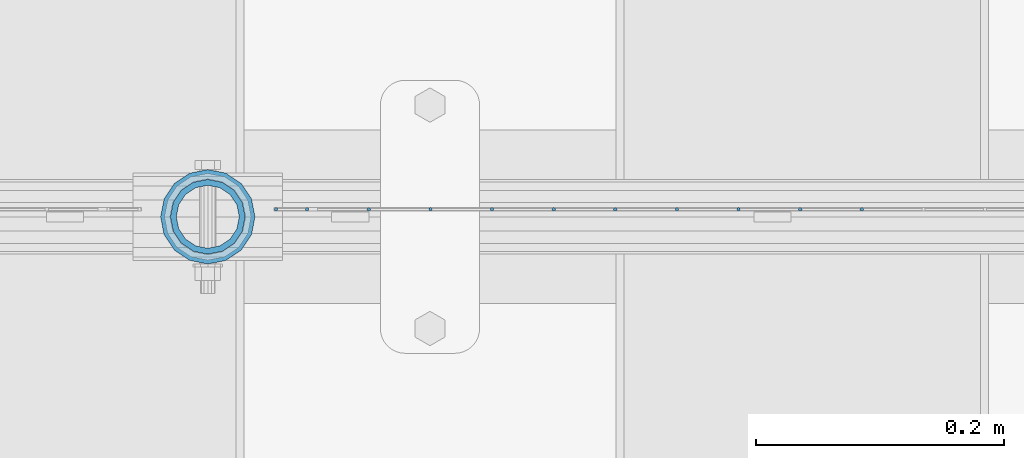
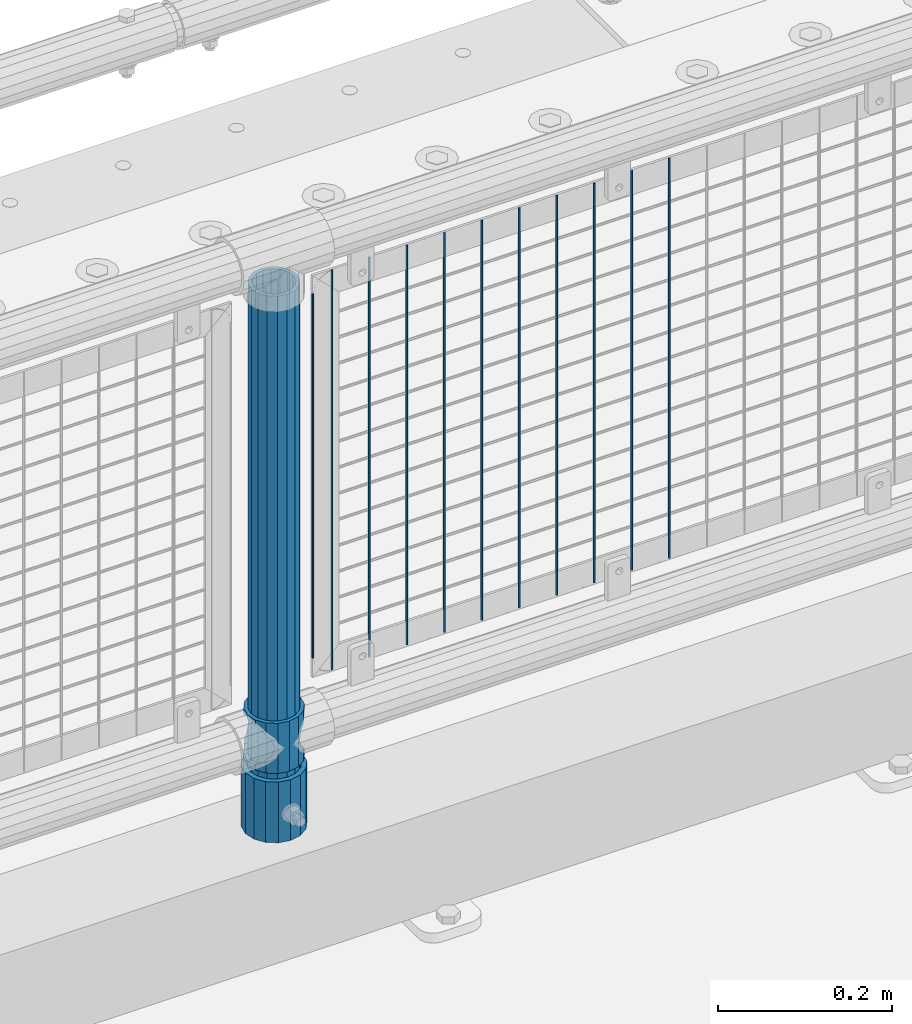
# One storey, part 96 of 247: 14 columns.
"""IFC2X3 building model written with IfcOpenShell, lengths in millimetres."""

from ifc_helpers import new_model, si_unit, frame, origin_with_axes, place, context, subcontext, project, spatial, faceted_brep, material, type_object, element, save


model = new_model("IFC2X3")

# Units and contexts
model_context = context("Model", 3, precision=1e-05, world=origin_with_axes())
body_context = subcontext(model_context, "Body", "Model", "MODEL_VIEW")
ifc_project = project(units=[si_unit("LENGTHUNIT", "METRE", prefix="MILLI"), si_unit("AREAUNIT", "SQUARE_METRE"), si_unit("VOLUMEUNIT", "CUBIC_METRE"), si_unit("MASSUNIT", "GRAM", prefix="KILO"), si_unit("TIMEUNIT", "SECOND"), si_unit("PLANEANGLEUNIT", "RADIAN"), si_unit("SOLIDANGLEUNIT", "STERADIAN"), si_unit("THERMODYNAMICTEMPERATUREUNIT", "DEGREE_CELSIUS"), si_unit("LUMINOUSINTENSITYUNIT", "LUMEN")], contexts=[model_context])

# Site, building, storey
site_placement = place(None, origin_with_axes())
site = spatial("IfcSite", under=ifc_project, at=site_placement, CompositionType="ELEMENT")
building_placement = place(site_placement, origin_with_axes())
building = spatial("IfcBuilding", under=site, at=building_placement, Name="Standard", CompositionType="ELEMENT")
storey_placement = place(building_placement, origin_with_axes())
storey = spatial("IfcBuildingStorey", under=building, at=storey_placement, Name="Undefined", CompositionType="ELEMENT", Elevation=0.0)

# Columns
ifc_material_1 = material()
column_type_1 = type_object("IfcColumnType", PredefinedType="NOTDEFINED")
column_1_placement = place(storey_placement, frame((13420.9999998042, 7664.5, 168.019999999998), z_axis=(0.0, 1.0, 0.0), x_axis=(0.0, 0.0, 1.0)))
element("IfcColumn", 1, at=column_1_placement, inside=storey, type_object=column_type_1, material=ifc_material_1, context=body_context, shape_type="Brep", body=[
    faceted_brep([(0.0, -31.75, 0.0), (0.0, -29.3331751572332, 12.1501989775916), (85.0, -29.3331751572332, 12.1501989775916), (85.0, -31.75, 0.0), (0.0, -22.4506403026735, 22.4506403026726), (85.0, -22.4506403026735, 22.4506403026726), (0.0, -12.1501989775916, 29.3331751572332), (85.0, -12.1501989775916, 29.3331751572332), (0.0, 0.0, 31.75), (85.0, 0.0, 31.75), (0.0, 12.1501989775916, 29.3331751572332), (85.0, 12.1501989775916, 29.3331751572332), (0.0, 22.4506403026735, 22.4506403026726), (85.0, 22.4506403026735, 22.4506403026726), (0.0, 29.3331751572332, 12.1501989775916), (85.0, 29.3331751572332, 12.1501989775916), (0.0, 31.75, 0.0), (85.0, 31.75, 0.0), (0.0, 29.3331751572332, -12.1501989775916), (85.0, 29.3331751572332, -12.1501989775916), (0.0, 22.4506403026735, -22.4506403026726), (85.0, 22.4506403026735, -22.4506403026726), (0.0, 12.1501989775916, -29.3331751572332), (85.0, 12.1501989775916, -29.3331751572332), (0.0, 0.0, -31.75), (85.0, 0.0, -31.75), (0.0, -12.1501989775916, -29.3331751572332), (85.0, -12.1501989775916, -29.3331751572332), (0.0, -22.4506403026735, -22.4506403026726), (85.0, -22.4506403026735, -22.4506403026726), (0.0, -29.3331751572332, -12.1501989775916), (85.0, -29.3331751572332, -12.1501989775916), (0.0, -38.0499999999993, 0.0), (0.0, -35.1536162120537, -14.5611046014919), (85.0, -35.1536162120537, -14.5611046014919), (85.0, -38.0499999999993, 0.0), (0.0, -26.9054130241475, -26.9054130241484), (85.0, -26.9054130241475, -26.9054130241484), (0.0, -14.561104601491, -35.1536162120547), (85.0, -14.561104601491, -35.1536162120547), (0.0, 0.0, -38.0500000000002), (85.0, 0.0, -38.0500000000002), (0.0, 14.561104601491, -35.1536162120547), (85.0, 14.561104601491, -35.1536162120547), (0.0, 26.9054130241475, -26.9054130241484), (85.0, 26.9054130241475, -26.9054130241484), (0.0, 35.1536162120537, -14.5611046014919), (85.0, 35.1536162120537, -14.5611046014919), (0.0, 38.0499999999993, 0.0), (85.0, 38.0499999999993, 0.0), (0.0, 35.1536162120537, 14.5611046014919), (85.0, 35.1536162120537, 14.5611046014919), (0.0, 26.9054130241475, 26.9054130241484), (85.0, 26.9054130241475, 26.9054130241484), (0.0, 14.561104601491, 35.1536162120547), (85.0, 14.561104601491, 35.1536162120547), (0.0, 0.0, 38.0500000000002), (85.0, 0.0, 38.0500000000002), (0.0, -14.561104601491, 35.1536162120547), (85.0, -14.561104601491, 35.1536162120547), (0.0, -26.9054130241475, 26.9054130241484), (85.0, -26.9054130241475, 26.9054130241484), (0.0, -35.1536162120537, 14.5611046014919), (85.0, -35.1536162120537, 14.5611046014919)], [[[0, 1, 2, 3]], [[1, 4, 5, 2]], [[4, 6, 7, 5]], [[6, 8, 9, 7]], [[8, 10, 11, 9]], [[10, 12, 13, 11]], [[12, 14, 15, 13]], [[14, 16, 17, 15]], [[16, 18, 19, 17]], [[18, 20, 21, 19]], [[20, 22, 23, 21]], [[22, 24, 25, 23]], [[24, 26, 27, 25]], [[26, 28, 29, 27]], [[28, 30, 31, 29]], [[30, 0, 3, 31]], [[32, 33, 34, 35]], [[33, 36, 37, 34]], [[36, 38, 39, 37]], [[38, 40, 41, 39]], [[40, 42, 43, 41]], [[42, 44, 45, 43]], [[44, 46, 47, 45]], [[46, 48, 49, 47]], [[48, 50, 51, 49]], [[50, 52, 53, 51]], [[52, 54, 55, 53]], [[54, 56, 57, 55]], [[56, 58, 59, 57]], [[58, 60, 61, 59]], [[60, 62, 63, 61]], [[62, 32, 35, 63]], [[37, 39, 41, 43, 45, 47, 49, 51, 53, 55, 57, 59, 61, 63, 35, 34], [5, 7, 9, 11, 13, 15, 17, 19, 21, 23, 25, 27, 29, 31, 3, 2]], [[62, 60, 58, 56, 54, 52, 50, 48, 46, 44, 42, 40, 38, 36, 33, 32], [30, 28, 26, 24, 22, 20, 18, 16, 14, 12, 10, 8, 6, 4, 1, 0]]]),
])
ifc_material_2 = material(Name="Misc_Undefined")
column_type_2 = type_object("IfcColumnType", PredefinedType="NOTDEFINED")
column_2_placement = place(storey_placement, frame((13421.0, 7664.5, 263.02), z_axis=(-1.0, 0.0, 0.0), x_axis=(0.0, 0.0, 1.0)))
element("IfcColumn", 2, at=column_2_placement, inside=storey, type_object=column_type_2, material=ifc_material_2, context=body_context, shape_type="Brep", body=[
    faceted_brep([(56.6106908090114, 21.4606908090118, -21.4606908090118), (56.6106908090114, 21.4606908090118, -27.1226768591096), (61.9623795176755, 13.4513226476329, -32.4743655677721), (63.1897438117172, 11.6144421722802, -32.839743811719), (63.1897438117172, 11.6144421722802, -28.0397438117179), (46.7644421722801, 28.0397438117179, -11.6144421722802), (46.7644421722801, 28.0397438117179, -20.088203122983), (51.5310424080055, 24.8548033587067, -24.8548033587067), (35.1499999999996, 30.35, 0.0), (35.1499999999996, 30.3500000000004, -16.6306603983649), (23.5355578277192, 28.0397438117179, -11.6144421722802), (23.5355578277192, 28.0397438117179, -20.088203122983), (13.6893091909879, 21.4606908090118, -21.4606908090118), (13.6893091909879, 21.4606908090118, -27.1226768591096), (18.768957591997, 24.8548033587067, -24.8548033587067), (7.11025618828211, 11.6144421722802, -28.0397438117179), (7.11025618828211, 11.6144421722802, -32.839743811719), (8.33762048232387, 13.4513226476329, -32.4743655677721), (4.79999999999961, 0.0, -30.3500000000004), (4.79999999999961, 0.0, -35.1499999999996), (7.11025618828211, -11.6144421722802, -28.0397438117179), (7.11025618828211, -11.6144421722802, -32.839743811719), (13.6893091909879, -21.4606908090118, -21.4606908090118), (13.6893091909879, -21.4606908090118, -27.1226768591077), (8.33762048232325, -13.4513226476329, -32.4743655677721), (23.5355578277191, -28.0397438117179, -11.6144421722802), (23.5355578277191, -28.0397438117179, -20.0882031229885), (18.768957591997, -24.8548033587067, -24.8548033587067), (35.1499999999996, -30.35, 0.0), (35.1499999999996, -30.3500000000004, -16.6306603983739), (46.7644421722801, -28.0397438117179, -11.6144421722802), (46.7644421722801, -28.0397438117179, -20.0882031229885), (56.6106908090114, -21.4606908090118, -21.4606908090118), (56.6106908090114, -21.4606908090118, -27.1226768591077), (51.5310424080038, -24.8548033587067, -24.8548033587067), (63.1897438117172, -11.6144421722802, -28.0397438117179), (63.1897438117172, -11.6144421722802, -32.839743811719), (61.9623795176754, -13.4513226476329, -32.4743655677721), (65.4999999999997, 0.0, -30.3500000000004), (65.4999999999997, 0.0, -35.1499999999996), (0.0, -28.0397438117179, -11.6144421722802), (0.0, -30.3500000000004, 0.0), (0.0, -21.4606908090118, -21.4606908090118), (0.0, -11.6144421722802, -28.0397438117179), (0.0, 0.0, -30.3500000000004), (0.0, 11.6144421722802, -28.0397438117179), (0.0, 21.4606908090118, -21.4606908090118), (0.0, 28.0397438117179, -11.6144421722802), (0.0, 30.3500000000004, 0.0), (0.0, 28.0397438117179, 11.6144421722802), (23.5355578277192, 28.0397438117179, 11.6144421722806), (0.0, 21.4606908090118, 21.4606908090118), (13.6893091909879, 21.4606908090118, 21.4606908090118), (0.0, 11.6144421722802, 28.0397438117179), (7.11025618828211, 11.6144421722802, 28.0397438117175), (0.0, 0.0, 30.3500000000004), (4.79999999999961, 0.0, 30.3499999999999), (0.0, -11.6144421722802, 28.0397438117179), (7.11025618828205, -11.6144421722802, 28.0397438117175), (0.0, -21.4606908090118, 21.4606908090118), (13.6893091909879, -21.4606908090118, 21.4606908090118), (0.0, -28.0397438117179, 11.6144421722802), (23.5355578277191, -28.0397438117179, 11.6144421722806), (0.0, -32.4743655677721, 13.4513226476338), (0.0, -35.1499999999996, 0.0), (70.2999999999993, -35.1499999999996, 0.0), (70.2999999999993, -32.4743655677721, 13.4513226476338), (0.0, 13.4513226476329, -32.4743655677721), (0.0, 24.8548033587067, -24.8548033587067), (0.0, 0.0, -35.1499999999996), (0.0, -13.4513226476329, -32.4743655677721), (0.0, -24.8548033587067, -24.8548033587067), (0.0, -24.8548033587067, 24.8548033587067), (0.0, -13.4513226476329, 32.4743655677721), (0.0, 0.0, 35.1499999999996), (0.0, 13.4513226476329, 32.4743655677721), (0.0, 24.8548033587067, 24.8548033587067), (0.0, 32.4743655677721, 13.4513226476338), (0.0, 35.1499999999996, 0.0), (0.0, 32.4743655677721, -13.4513226476338), (0.0, -32.4743655677721, -13.4513226476338), (70.2999999999993, 32.4743655677721, 13.4513226476338), (70.2999999999993, 35.1499999999996, 0.0), (70.2999999999993, 32.4743655677721, -13.4513226476338), (70.2999999999993, 24.8548033587067, -24.8548033587067), (70.2999999999993, 13.4513226476329, -32.4743655677721), (70.2999999999993, 0.0, -35.1499999999996), (70.2999999999993, -13.4513226476329, -32.4743655677721), (70.2999999999993, -24.8548033587067, -24.8548033587067), (70.2999999999993, -32.4743655677721, -13.4513226476338), (70.2999999999993, 28.0397438117179, 11.6144421722802), (70.2999999999993, 21.4606908090118, 21.4606908090118), (56.6106908090114, 21.4606908090118, 21.4606908090118), (46.7644421722801, 28.0397438117179, 11.6144421722806), (70.2999999999993, 11.6144421722802, 28.0397438117179), (63.1897438117172, 11.6144421722802, 28.0397438117175), (70.2999999999993, 0.0, 30.3500000000004), (65.4999999999997, 0.0, 30.3499999999999), (70.2999999999993, -11.6144421722802, 28.0397438117179), (63.1897438117172, -11.6144421722802, 28.0397438117175), (70.2999999999993, -21.4606908090118, 21.4606908090118), (56.6106908090114, -21.4606908090118, 21.4606908090118), (70.2999999999993, -28.0397438117179, 11.6144421722802), (46.7644421722801, -28.0397438117179, 11.6144421722806), (70.2999999999993, -11.6144421722802, -28.0397438117179), (70.2999999999993, 0.0, -30.3500000000004), (70.2999999999993, -21.4606908090118, -21.4606908090118), (70.2999999999993, -28.0397438117179, -11.6144421722802), (70.2999999999993, -30.3500000000004, 0.0), (70.2999999999993, 24.8548033587067, 24.8548033587067), (70.2999999999993, 13.4513226476329, 32.4743655677721), (70.2999999999993, 0.0, 35.1499999999996), (70.2999999999993, -13.4513226476329, 32.4743655677721), (70.2999999999993, -24.8548033587067, 24.8548033587067), (70.2999999999993, 30.3500000000004, 0.0), (70.2999999999993, 28.0397438117179, -11.6144421722802), (70.2999999999993, 21.4606908090118, -21.4606908090118), (70.2999999999993, 11.6144421722802, -28.0397438117179), (61.9623795176755, 13.4513226476329, 32.4743655677717), (51.5310424080043, 24.8548033587067, 24.8548033587072), (56.6106908090114, 21.4606908090118, 27.1226768591082), (65.4999999999997, 0.0, 35.1500000000001), (63.1897438117172, 11.6144421722802, 32.8397438117177), (63.1897438117172, -11.6144421722802, 32.8397438117177), (61.962379517675, -13.4513226476329, 32.4743655677717), (56.6106908090114, -21.4606908090118, 27.1226768591068), (51.5310424080026, -24.8548033587067, 24.8548033587072), (18.7689575919956, -24.8548033587067, 24.8548033587072), (46.7644421722801, -28.0397438117179, 20.088203122983), (35.1499999999996, -30.3500000000004, 16.6306603983649), (23.5355578277191, -28.0397438117179, 20.088203122983), (8.33762048232268, -13.4513226476329, 32.4743655677717), (13.6893091909879, -21.4606908090118, 27.1226768591068), (4.79999999999961, 0.0, 35.1500000000001), (7.11025618828205, -11.6144421722802, 32.8397438117177), (7.11025618828211, 11.6144421722802, 32.8397438117177), (8.33762048232427, 13.4513226476329, 32.4743655677717), (13.6893091909879, 21.4606908090118, 27.1226768591082), (18.7689575919966, 24.8548033587067, 24.8548033587072), (23.5355578277192, 28.0397438117179, 20.0882031229844), (35.1499999999996, 30.3500000000004, 16.6306603983667), (46.7644421722801, 28.0397438117179, 20.0882031229844)], [[[0, 1, 2, 3, 4]], [[5, 6, 7, 1, 0]], [[8, 9, 6, 5]], [[10, 11, 9, 8]], [[12, 13, 14, 11, 10]], [[15, 16, 17, 13, 12]], [[18, 19, 16, 15]], [[20, 21, 19, 18]], [[22, 23, 24, 21, 20]], [[25, 26, 27, 23, 22]], [[28, 29, 26, 25]], [[30, 31, 29, 28]], [[32, 33, 34, 31, 30]], [[35, 36, 37, 33, 32]], [[38, 39, 36, 35]], [[4, 3, 39, 38]], [[40, 41, 28, 25]], [[42, 40, 25, 22]], [[43, 42, 22, 20]], [[44, 43, 20, 18]], [[45, 44, 18, 15]], [[46, 45, 15, 12]], [[47, 46, 12, 10]], [[48, 47, 10, 8]], [[49, 48, 8, 50]], [[51, 49, 50, 52]], [[53, 51, 52, 54]], [[55, 53, 54, 56]], [[57, 55, 56, 58]], [[59, 57, 58, 60]], [[61, 59, 60, 62]], [[41, 61, 62, 28]], [[63, 64, 65, 66]], [[17, 67, 68, 14, 13]], [[19, 69, 67, 17, 16]], [[70, 69, 19, 21, 24]], [[71, 70, 24, 23, 27]], [[63, 72, 73, 74, 75, 76, 77, 78, 79, 68, 67, 69, 70, 71, 80, 64], [40, 42, 43, 44, 45, 46, 47, 48, 49, 51, 53, 55, 57, 59, 61, 41]], [[78, 77, 81, 82]], [[79, 78, 82, 83]], [[14, 68, 79, 83, 84, 7, 6, 9, 11]], [[84, 85, 2, 1, 7]], [[85, 86, 39, 3, 2]], [[37, 87, 88, 34, 33]], [[39, 86, 87, 37, 36]], [[34, 88, 89, 80, 71, 27, 26, 29, 31]], [[64, 80, 89, 65]], [[90, 91, 92, 93]], [[91, 94, 95, 92]], [[94, 96, 97, 95]], [[96, 98, 99, 97]], [[98, 100, 101, 99]], [[100, 102, 103, 101]], [[104, 105, 38, 35]], [[106, 104, 35, 32]], [[107, 106, 32, 30]], [[108, 107, 30, 28]], [[102, 108, 28, 103]], [[88, 87, 86, 85, 84, 83, 82, 81, 109, 110, 111, 112, 113, 66, 65, 89], [100, 98, 96, 94, 91, 90, 114, 115, 116, 117, 105, 104, 106, 107, 108, 102]], [[118, 110, 109, 119, 120]], [[121, 111, 110, 118, 122]], [[112, 111, 121, 123, 124]], [[113, 112, 124, 125, 126]], [[127, 72, 63, 66, 113, 126, 128, 129, 130]], [[131, 73, 72, 127, 132]], [[133, 74, 73, 131, 134]], [[75, 74, 133, 135, 136]], [[76, 75, 136, 137, 138]], [[119, 109, 81, 77, 76, 138, 139, 140, 141]], [[92, 120, 119, 141, 93]], [[95, 122, 118, 120, 92]], [[97, 121, 122, 95]], [[99, 123, 121, 97]], [[101, 125, 124, 123, 99]], [[103, 128, 126, 125, 101]], [[28, 129, 128, 103]], [[62, 130, 129, 28]], [[60, 132, 127, 130, 62]], [[58, 134, 131, 132, 60]], [[56, 133, 134, 58]], [[54, 135, 133, 56]], [[52, 137, 136, 135, 54]], [[50, 139, 138, 137, 52]], [[8, 140, 139, 50]], [[93, 141, 140, 8]], [[114, 90, 93, 8]], [[115, 114, 8, 5]], [[116, 115, 5, 0]], [[117, 116, 0, 4]], [[105, 117, 4, 38]]]),
])
column_type_3 = type_object("IfcColumnType", PredefinedType="NOTDEFINED")
column_3_placement = place(storey_placement, frame((13420.9999998042, 7664.5, 168.019999999998), z_axis=(-1.0, 0.0, 0.0), x_axis=(0.0, 0.0, 1.0)))
element("IfcColumn", 3, at=column_3_placement, inside=storey, type_object=column_type_3, material=ifc_material_1, context=body_context, shape_type="Brep", body=[
    faceted_brep([(0.0, -25.3500000000004, 0.0), (0.0, -23.4203461491616, 9.70102501045585), (760.0, -23.4203461491616, 9.70102501045585), (760.0, -25.3500000000004, 0.0), (0.0, -17.9251569030794, 17.9251569030785), (760.0, -17.9251569030794, 17.9251569030785), (0.0, -9.70102501045494, 23.4203461491616), (760.0, -9.70102501045494, 23.4203461491616), (0.0, 0.0, 25.3500000000004), (760.0, 0.0, 25.3500000000004), (0.0, 9.70102501045494, 23.4203461491616), (760.0, 9.70102501045494, 23.4203461491616), (0.0, 17.9251569030794, 17.9251569030785), (760.0, 17.9251569030794, 17.9251569030785), (0.0, 23.4203461491616, 9.70102501045585), (760.0, 23.4203461491616, 9.70102501045585), (0.0, 25.3500000000004, 0.0), (760.0, 25.3500000000004, 0.0), (0.0, 23.4203461491616, -9.70102501045585), (760.0, 23.4203461491616, -9.70102501045585), (0.0, 17.9251569030794, -17.9251569030785), (760.0, 17.9251569030794, -17.9251569030785), (0.0, 9.70102501045494, -23.4203461491616), (760.0, 9.70102501045494, -23.4203461491616), (0.0, 0.0, -25.3500000000004), (760.0, 0.0, -25.3500000000004), (0.0, -9.70102501045494, -23.4203461491616), (760.0, -9.70102501045494, -23.4203461491616), (0.0, -17.9251569030794, -17.9251569030785), (760.0, -17.9251569030794, -17.9251569030785), (0.0, -23.4203461491616, -9.70102501045585), (760.0, -23.4203461491616, -9.70102501045585), (0.0, -30.1499999999996, 0.0), (0.0, -27.8549679052148, -11.5379054858076), (760.0, -27.8549679052148, -11.5379054858076), (760.0, -30.1499999999996, 0.0), (0.0, -21.3192694527743, -21.3192694527752), (760.0, -21.3192694527743, -21.3192694527752), (0.0, -11.5379054858076, -27.8549679052157), (760.0, -11.5379054858076, -27.8549679052157), (0.0, 0.0, -30.1499999999996), (760.0, 0.0, -30.1499999999996), (0.0, 11.5379054858076, -27.8549679052157), (760.0, 11.5379054858076, -27.8549679052157), (0.0, 21.3192694527743, -21.3192694527752), (760.0, 21.3192694527743, -21.3192694527752), (0.0, 27.8549679052157, -11.5379054858076), (760.0, 27.8549679052157, -11.5379054858076), (0.0, 30.1499999999996, 0.0), (760.0, 30.1499999999996, 0.0), (0.0, 27.8549679052157, 11.5379054858076), (760.0, 27.8549679052157, 11.5379054858076), (0.0, 21.3192694527743, 21.3192694527752), (760.0, 21.3192694527743, 21.3192694527752), (0.0, 11.5379054858076, 27.8549679052157), (760.0, 11.5379054858076, 27.8549679052157), (0.0, 0.0, 30.1499999999996), (760.0, 0.0, 30.1499999999996), (0.0, -11.5379054858076, 27.8549679052157), (760.0, -11.5379054858076, 27.8549679052157), (0.0, -21.3192694527743, 21.3192694527752), (760.0, -21.3192694527743, 21.3192694527752), (0.0, -27.8549679052157, 11.5379054858076), (760.0, -27.8549679052157, 11.5379054858076)], [[[0, 1, 2, 3]], [[1, 4, 5, 2]], [[4, 6, 7, 5]], [[6, 8, 9, 7]], [[8, 10, 11, 9]], [[10, 12, 13, 11]], [[12, 14, 15, 13]], [[14, 16, 17, 15]], [[16, 18, 19, 17]], [[18, 20, 21, 19]], [[20, 22, 23, 21]], [[22, 24, 25, 23]], [[24, 26, 27, 25]], [[26, 28, 29, 27]], [[28, 30, 31, 29]], [[30, 0, 3, 31]], [[32, 33, 34, 35]], [[33, 36, 37, 34]], [[36, 38, 39, 37]], [[38, 40, 41, 39]], [[40, 42, 43, 41]], [[42, 44, 45, 43]], [[44, 46, 47, 45]], [[46, 48, 49, 47]], [[48, 50, 51, 49]], [[50, 52, 53, 51]], [[52, 54, 55, 53]], [[54, 56, 57, 55]], [[56, 58, 59, 57]], [[58, 60, 61, 59]], [[60, 62, 63, 61]], [[62, 32, 35, 63]], [[37, 39, 41, 43, 45, 47, 49, 51, 53, 55, 57, 59, 61, 63, 35, 34], [5, 7, 9, 11, 13, 15, 17, 19, 21, 23, 25, 27, 29, 31, 3, 2]], [[62, 60, 58, 56, 54, 52, 50, 48, 46, 44, 42, 40, 38, 36, 33, 32], [30, 28, 26, 24, 22, 20, 18, 16, 14, 12, 10, 8, 6, 4, 1, 0]]]),
])
column_type_4 = type_object("IfcColumnType", Name="D3", PredefinedType="NOTDEFINED")
for number, where, z_axis, x_axis in (
    (4, (13947.895, 7670.50000000001, 353.020000000006), (-1.0, 0.0, 0.0), (0.0, 0.0, 1.0)),
    (5, (13898.24, 7670.50000000001, 353.020000000006), (-1.0, 0.0, 0.0), (0.0, 0.0, 1.0)),
    (6, (13848.585, 7670.50000000001, 353.020000000006), (-1.0, 0.0, 0.0), (0.0, 0.0, 1.0)),
    (7, (13798.93, 7670.50000000001, 353.020000000006), (-1.0, 0.0, 0.0), (0.0, 0.0, 1.0)),
    (8, (13749.275, 7670.50000000001, 353.020000000006), (-1.0, 0.0, 0.0), (0.0, 0.0, 1.0)),
    (9, (13699.62, 7670.50000000001, 353.020000000006), (-1.0, 0.0, 0.0), (0.0, 0.0, 1.0)),
    (10, (13649.965, 7670.50000000001, 353.020000000006), (-1.0, 0.0, 0.0), (0.0, 0.0, 1.0)),
    (11, (13600.3103448276, 7670.50000000001, 353.020000000006), (-1.0, 0.0, 0.0), (0.0, 0.0, 1.0)),
    (12, (13550.6551724138, 7670.50000000001, 353.020000000006), (-0.999999999962839, 0.0, 8.62099999968473e-06), (8.62099999949798e-06, 0.0, 0.999999999962839)),
):
    element("IfcColumn", number, at=place(storey_placement, frame(where, z_axis=z_axis, x_axis=x_axis)), inside=storey, type_object=column_type_4, material=ifc_material_2, ObjectType="D3", context=body_context, shape_type="Brep", body=[
        faceted_brep([(1.81898940354586e-12, -1.5, -5.6843418860808e-14), (0.0, -0.75, -1.29903810567703), (560.0, -0.75, -1.29903810567703), (560.0, -1.5, 0.0), (0.0, 0.75, -1.29903810567703), (560.0, 0.75, -1.29903810567703), (1.81898940354586e-12, 1.5, -5.6843418860808e-14), (560.0, 1.5, 0.0), (0.0, 0.75, 1.29903810567703), (560.0, 0.75, 1.29903810567703), (0.0, -0.75, 1.29903810567703), (560.0, -0.75, 1.29903810567703)], [[[0, 1, 2, 3]], [[1, 4, 5, 2]], [[4, 6, 7, 5]], [[6, 8, 9, 7]], [[8, 10, 11, 9]], [[10, 0, 3, 11]], [[5, 7, 9, 11, 3, 2]], [[10, 8, 6, 4, 1, 0]]]),
    ])
column_4_placement = place(storey_placement, frame((13476.0, 7670.50000000001, 378.020000000006), z_axis=(-1.0, 0.0, 0.0), x_axis=(0.0, 0.0, 1.0)))
element("IfcColumn", 13, at=column_4_placement, inside=storey, type_object=column_type_4, material=ifc_material_2, ObjectType="D3", context=body_context, shape_type="Brep", body=[
    faceted_brep([(1.81898940354586e-12, -1.5, -5.6843418860808e-14), (0.0, -0.75, -1.29903810567703), (510.0, -0.75, -1.29903810567703), (510.0, -1.5, 0.0), (0.0, 0.75, -1.29903810567703), (510.0, 0.75, -1.29903810567703), (1.81898940354586e-12, 1.5, -5.6843418860808e-14), (510.0, 1.5, 0.0), (0.0, 0.75, 1.29903810567703), (510.0, 0.75, 1.29903810567703), (0.0, -0.75, 1.29903810567703), (510.0, -0.75, 1.29903810567703)], [[[0, 1, 2, 3]], [[1, 4, 5, 2]], [[4, 6, 7, 5]], [[6, 8, 9, 7]], [[8, 10, 11, 9]], [[10, 0, 3, 11]], [[5, 7, 9, 11, 3, 2]], [[10, 8, 6, 4, 1, 0]]]),
])
column_5_placement = place(storey_placement, frame((13501.0, 7670.50000000001, 353.020000000006), z_axis=(-1.0, 0.0, 0.0), x_axis=(0.0, 0.0, 1.0)))
element("IfcColumn", 14, at=column_5_placement, inside=storey, type_object=column_type_4, material=ifc_material_2, ObjectType="D3", context=body_context, shape_type="Brep", body=[
    faceted_brep([(1.81898940354586e-12, -1.5, -5.6843418860808e-14), (0.0, -0.75, -1.29903810567703), (560.0, -0.75, -1.29903810567703), (560.0, -1.5, 0.0), (0.0, 0.75, -1.29903810567703), (560.0, 0.75, -1.29903810567703), (1.81898940354586e-12, 1.5, -5.6843418860808e-14), (560.0, 1.5, 0.0), (0.0, 0.75, 1.29903810567703), (560.0, 0.75, 1.29903810567703), (0.0, -0.75, 1.29903810567703), (560.0, -0.75, 1.29903810567703)], [[[0, 1, 2, 3]], [[1, 4, 5, 2]], [[4, 6, 7, 5]], [[6, 8, 9, 7]], [[8, 10, 11, 9]], [[10, 0, 3, 11]], [[5, 7, 9, 11, 3, 2]], [[10, 8, 6, 4, 1, 0]]]),
])

save(model, "model.ifc")
